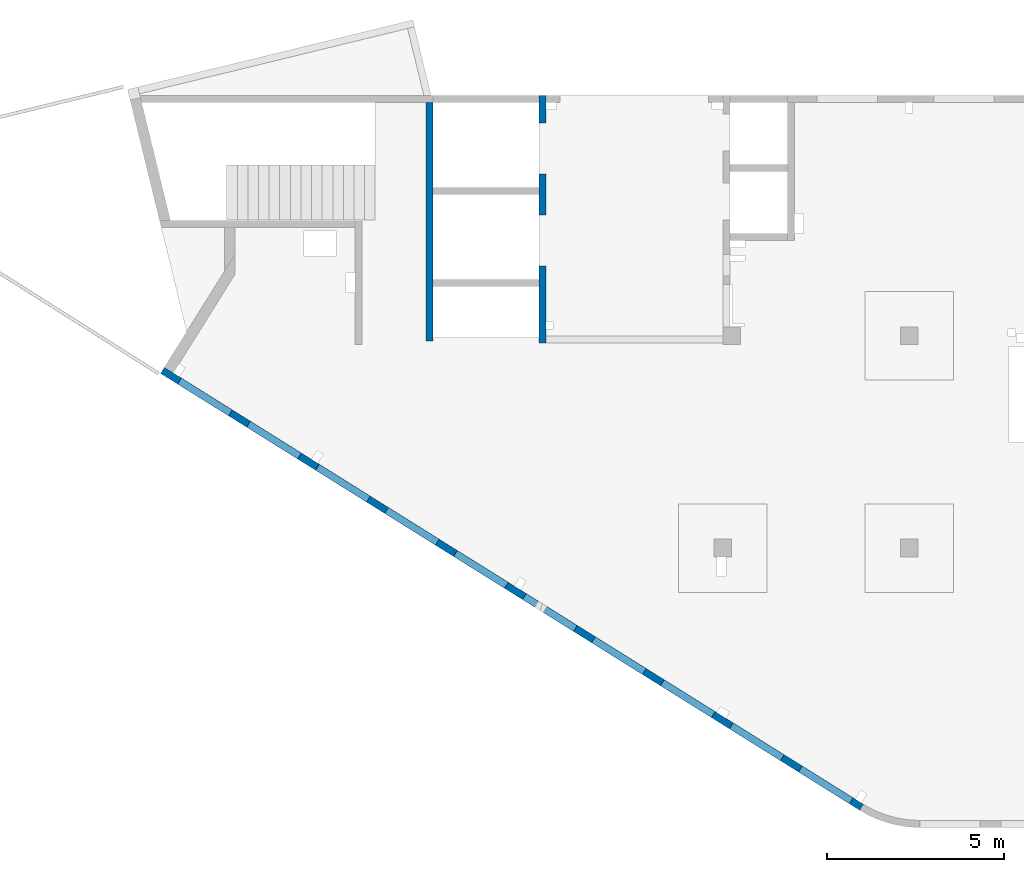
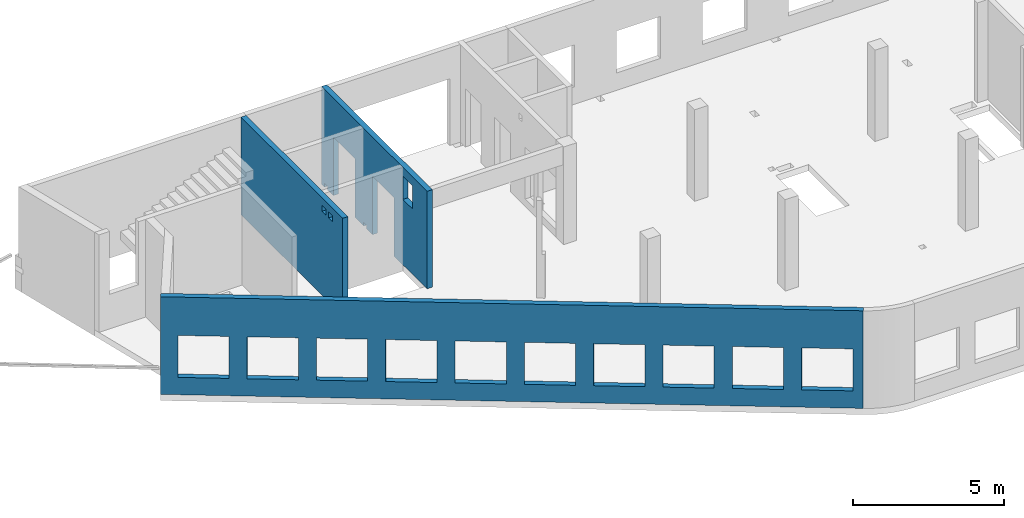
# One storey, part 5 of 8: 3 walls, 17 openings.
"""IFC4 building model written with IfcOpenShell, lengths in millimetres."""

import ifcopenshell
import ifcopenshell.guid

model = None  # the IFC model being written
_history = None  # IfcOwnerHistory: only IFC2X3 demands one
_inside = {}  # id of a spatial element -> (the spatial element, [elements in it])
_under = {}  # id of a project, library or spatial element -> (it, [spatial elements below it])
_declared = {}  # id of a project -> (the project, [libraries it declares])
_typed = {}  # id of a type object -> (the type object, [elements of that type])
_made_of = {}  # id of a material, layer set ... -> (it, [elements and type objects made of it])


def new_model(schema):
    """Start an empty IFC model of exactly this schema.

    Asked for "IFC4X3", IfcOpenShell would pick the latest addendum, in which some entities
    have other attributes; the version numbers below select the first issue.
    IFC2X3 requires an IfcOwnerHistory on every rooted entity: one is made here for all.
    """
    global model, _history
    if schema == "IFC4X3":
        model = ifcopenshell.file(schema_version=(4, 3, 0, 0))
    else:
        model = ifcopenshell.file(schema=schema)
    _inside.clear()
    _under.clear()
    _declared.clear()
    _typed.clear()
    _made_of.clear()
    _history = None
    if model.schema == "IFC2X3":
        org = make("IfcOrganization", Name="unknown")
        user = make(
            "IfcPersonAndOrganization",
            ThePerson=make("IfcPerson", FamilyName="unknown"),
            TheOrganization=org,
        )
        app = make(
            "IfcApplication",
            ApplicationDeveloper=org,
            Version="unknown",
            ApplicationFullName="unknown",
            ApplicationIdentifier="unknown",
        )
        _history = make(
            "IfcOwnerHistory",
            OwningUser=user,
            OwningApplication=app,
            ChangeAction="ADDED",
            CreationDate=0,
        )
    return model


def make(cls, **values):
    """One entity of the class cls with the attributes given. An attribute that is None is left unset."""
    return model.create_entity(
        cls, **{name: value for name, value in values.items() if value is not None}
    )


def entity(cls, *values):
    """Any entity or typed value of the class cls, its attributes in the order of the schema. None: left unset."""
    e = model.create_entity(cls)
    for i, value in enumerate(values):
        if value is not None:
            e[i] = value
    return e


def rooted(cls, **values):
    """An entity with a GlobalId (a new one), such as an element, a storey or a relation."""
    return make(cls, GlobalId=ifcopenshell.guid.new(), OwnerHistory=_history, **values)


def si_unit(unit_type, name, prefix=None):
    """IfcSIUnit, for example si_unit("LENGTHUNIT", "METRE", prefix="MILLI")."""
    return make("IfcSIUnit", UnitType=unit_type, Prefix=prefix, Name=name)


def converted_unit(unit_type, name, factor, base, dimensions=None, offset=None):
    """IfcConversionBasedUnit, such as the inch: factor (a typed value) times the base unit."""
    return make(
        "IfcConversionBasedUnit"
        if offset is None
        else "IfcConversionBasedUnitWithOffset",
        ConversionOffset=offset,
        Dimensions=None
        if dimensions is None
        else entity("IfcDimensionalExponents", *dimensions),
        UnitType=unit_type,
        Name=name,
        ConversionFactor=make(
            "IfcMeasureWithUnit", ValueComponent=factor, UnitComponent=base
        ),
    )


def derived_unit(unit_type, elements):
    """IfcDerivedUnit: a product of units, each with its exponent."""
    return make(
        "IfcDerivedUnit",
        Elements=[
            make("IfcDerivedUnitElement", Unit=unit, Exponent=power)
            for unit, power in elements
        ],
        UnitType=unit_type,
    )


def assignment(units):
    """IfcUnitAssignment: the units of a project."""
    return None if units is None else make("IfcUnitAssignment", Units=units)


def point(xyz):
    """IfcCartesianPoint."""
    return None if xyz is None else make("IfcCartesianPoint", Coordinates=xyz)


def direction(xyz):
    """IfcDirection."""
    return None if xyz is None else make("IfcDirection", DirectionRatios=xyz)


def frame(location, z_axis=None, x_axis=None):
    """IfcAxis2Placement3D, a coordinate frame: its origin and axes. An axis left out is left unset."""
    return make(
        "IfcAxis2Placement3D",
        Location=point(location),
        Axis=direction(z_axis),
        RefDirection=direction(x_axis),
    )


def origin():
    """The frame at (0, 0, 0) with its axes left unset."""
    return frame((0.0, 0.0, 0.0))


def place(relative_to, where):
    """IfcLocalPlacement: puts the frame where relative to a parent placement (None: the world)."""
    return make(
        "IfcLocalPlacement", PlacementRelTo=relative_to, RelativePlacement=where
    )


def context(
    kind, dimensions, precision=None, world=None, true_north=None, identifier=None
):
    """IfcGeometricRepresentationContext, for example the 3D "Model" context."""
    return make(
        "IfcGeometricRepresentationContext",
        ContextIdentifier=identifier,
        ContextType=kind,
        CoordinateSpaceDimension=dimensions,
        Precision=precision,
        WorldCoordinateSystem=world,
        TrueNorth=true_north,
    )


def subcontext(parent, identifier, kind, view, scale=None):
    """IfcGeometricRepresentationSubContext, for example "Body" below "Model"."""
    return make(
        "IfcGeometricRepresentationSubContext",
        ContextIdentifier=identifier,
        ContextType=kind,
        ParentContext=parent,
        TargetScale=scale,
        TargetView=view,
    )


def project(units=None, contexts=None):
    """IfcProject with its units and contexts."""
    return rooted(
        "IfcProject",
        Name="project",
        RepresentationContexts=contexts,
        UnitsInContext=assignment(units),
    )


def spatial(cls, under=None, at=None, **own):
    """A site, building, storey or space (cls), placed at a placement, below another one or the project."""
    s = rooted(cls, ObjectPlacement=at, **own)
    if under is not None:
        _under.setdefault(under.id(), (under, []))[1].append(s)
    return s


def point_list(points):
    """IfcCartesianPointList2D or 3D."""
    cls = (
        "IfcCartesianPointList2D" if len(points[0]) == 2 else "IfcCartesianPointList3D"
    )
    return make(cls, CoordList=points)


def indexed_curve(points, segments=None, self_intersect=None):
    """IfcIndexedPolyCurve: lines and arcs through numbered points (the first is 1)."""
    return make(
        "IfcIndexedPolyCurve",
        Points=point_list(points),
        Segments=segments,
        SelfIntersect=self_intersect,
    )


def outline(outer, holes=None, kind="AREA"):
    """IfcArbitraryClosedProfileDef: a profile drawn as a closed curve; with holes, ...WithVoids."""
    if holes is None:
        return make("IfcArbitraryClosedProfileDef", ProfileType=kind, OuterCurve=outer)
    return make(
        "IfcArbitraryProfileDefWithVoids",
        ProfileType=kind,
        OuterCurve=outer,
        InnerCurves=holes,
    )


def extrude(swept, where, along, depth):
    """IfcExtrudedAreaSolid: the profile swept, set in the frame where, extruded along a direction by depth."""
    return make(
        "IfcExtrudedAreaSolid",
        SweptArea=swept,
        Position=where,
        ExtrudedDirection=direction(along),
        Depth=depth,
    )


def polygons(points, faces, closed=None, point_numbers=None):
    """IfcPolygonalFaceSet: a face is its outer loop, then its inner loops; points numbered from 1."""
    made = []
    for loops in faces:
        if len(loops) == 1:
            made.append(make("IfcIndexedPolygonalFace", CoordIndex=loops[0]))
        else:
            made.append(
                make(
                    "IfcIndexedPolygonalFaceWithVoids",
                    CoordIndex=loops[0],
                    InnerCoordIndices=loops[1:],
                )
            )
    return make(
        "IfcPolygonalFaceSet",
        Coordinates=point_list(points),
        Closed=closed,
        Faces=made,
        PnIndex=point_numbers,
    )


def shape(context_of_items, identifier, shape_type, items):
    """IfcShapeRepresentation: the items that make up one representation, for example the "Body"."""
    return make(
        "IfcShapeRepresentation",
        ContextOfItems=context_of_items,
        RepresentationIdentifier=identifier,
        RepresentationType=shape_type,
        Items=items,
    )


def material(Name=None, Category=None):
    """IfcMaterial."""
    return make("IfcMaterial", Name=Name, Category=Category)


def made_of(thing, what):
    """Note that an element or type object is made of a material, layer set ...; save() writes the relation."""
    if what is not None:
        _made_of.setdefault(what.id(), (what, []))[1].append(thing)
    return thing


def type_object(cls, material=None, **own):
    """A type object (cls), such as IfcWallType, which elements share."""
    return made_of(rooted(cls, **own), material)


def element(
    cls,
    number,
    at=None,
    inside=None,
    cuts=None,
    type_object=None,
    material=None,
    context=None,
    identifier="Body",
    shape_type=None,
    held_by="IfcProductDefinitionShape",
    body=None,
    shapes=None,
    **own,
):
    """One element of the class cls, such as IfcWall. Its Tag is "e" and its number.

    at: its placement. inside: the storey or other place that contains it. cuts: it is an
    opening in that element (IfcRelVoidsElement). A single representation is given by context,
    identifier, shape_type and body (its items); several are given by shapes. held_by: the class
    of the entity that holds the representations. save() writes the other relations.
    """
    e = rooted(cls, Tag="e%d" % number, ObjectPlacement=at, **own)
    if body is not None:
        shapes = [shape(context, identifier, shape_type, body)]
    if shapes is not None:
        e.Representation = make(held_by, Representations=shapes)
    if inside is not None:
        _inside.setdefault(inside.id(), (inside, []))[1].append(e)
    if cuts is not None:
        rooted(
            "IfcRelVoidsElement", RelatingBuildingElement=cuts, RelatedOpeningElement=e
        )
    if type_object is not None:
        _typed.setdefault(type_object.id(), (type_object, []))[1].append(e)
    return made_of(e, material)


def aggregate(whole, parts):
    """IfcRelAggregates: a whole, such as a stair, and the parts it consists of."""
    return rooted("IfcRelAggregates", RelatingObject=whole, RelatedObjects=parts)


def save(model, path):
    """Write the relations noted so far, then the file.

    IfcRelAggregates (storeys below a building ...), IfcRelContainedInSpatialStructure (elements
    in a storey), IfcRelDefinesByType, IfcRelAssociatesMaterial and IfcRelDeclares: one each for
    every whole, place, type object, material and project.
    """
    for whole, parts in _under.values():
        aggregate(whole, parts)
    for where, things in _inside.values():
        rooted(
            "IfcRelContainedInSpatialStructure",
            RelatedElements=things,
            RelatingStructure=where,
        )
    for kind, things in _typed.values():
        rooted("IfcRelDefinesByType", RelatedObjects=things, RelatingType=kind)
    for what, things in _made_of.values():
        rooted("IfcRelAssociatesMaterial", RelatedObjects=things, RelatingMaterial=what)
    for by, libraries in _declared.values():
        rooted("IfcRelDeclares", RelatingContext=by, RelatedDefinitions=libraries)
    model.write(path)


model = new_model("IFC4")

# Units and contexts
model_context = context("Model", 3, precision=0.01, world=origin(), true_north=direction((6.12303176911189e-17, 1.0)))
plan_context = context("Plan", 3, precision=0.01, world=origin(), true_north=direction((6.12303176911189e-17, 1.0)))
body_context = subcontext(model_context, "Body", "Model", "MODEL_VIEW")
ifc_project = project(units=[si_unit("LENGTHUNIT", "METRE", prefix="MILLI"), si_unit("AREAUNIT", "SQUARE_METRE"), si_unit("VOLUMEUNIT", "CUBIC_METRE"), converted_unit("PLANEANGLEUNIT", "DEGREE", entity("IfcRatioMeasure", 0.0174532925199433), si_unit("PLANEANGLEUNIT", "RADIAN"), dimensions=[0, 0, 0, 0, 0, 0, 0]), si_unit("MASSUNIT", "GRAM", prefix="KILO"), derived_unit("MASSDENSITYUNIT", [(si_unit("MASSUNIT", "GRAM", prefix="KILO"), 1), (si_unit("LENGTHUNIT", "METRE"), -3)]), derived_unit("MOMENTOFINERTIAUNIT", [(si_unit("LENGTHUNIT", "METRE"), 4)]), si_unit("TIMEUNIT", "SECOND"), si_unit("FREQUENCYUNIT", "HERTZ"), si_unit("THERMODYNAMICTEMPERATUREUNIT", "DEGREE_CELSIUS"), derived_unit("THERMALTRANSMITTANCEUNIT", [(si_unit("MASSUNIT", "GRAM", prefix="KILO"), 1), (si_unit("THERMODYNAMICTEMPERATUREUNIT", "KELVIN"), -1), (si_unit("TIMEUNIT", "SECOND"), -3)]), derived_unit("VOLUMETRICFLOWRATEUNIT", [(si_unit("LENGTHUNIT", "METRE"), 3), (si_unit("TIMEUNIT", "SECOND"), -1)]), derived_unit("MASSFLOWRATEUNIT", [(si_unit("MASSUNIT", "GRAM", prefix="KILO"), 1), (si_unit("TIMEUNIT", "SECOND"), -1)]), derived_unit("ROTATIONALFREQUENCYUNIT", [(si_unit("TIMEUNIT", "SECOND"), -1)]), si_unit("ELECTRICCURRENTUNIT", "AMPERE"), si_unit("ELECTRICVOLTAGEUNIT", "VOLT"), si_unit("POWERUNIT", "WATT"), si_unit("FORCEUNIT", "NEWTON", prefix="KILO"), si_unit("ILLUMINANCEUNIT", "LUX"), si_unit("LUMINOUSFLUXUNIT", "LUMEN"), si_unit("LUMINOUSINTENSITYUNIT", "CANDELA"), derived_unit("USERDEFINED", [(si_unit("MASSUNIT", "GRAM", prefix="KILO"), -1), (si_unit("LENGTHUNIT", "METRE"), -2), (si_unit("TIMEUNIT", "SECOND"), 3), (si_unit("LUMINOUSFLUXUNIT", "LUMEN"), 1)]), derived_unit("LINEARVELOCITYUNIT", [(si_unit("LENGTHUNIT", "METRE"), 1), (si_unit("TIMEUNIT", "SECOND"), -1)]), si_unit("PRESSUREUNIT", "PASCAL"), derived_unit("USERDEFINED", [(si_unit("LENGTHUNIT", "METRE"), -2), (si_unit("MASSUNIT", "GRAM", prefix="KILO"), 1), (si_unit("TIMEUNIT", "SECOND"), -2)]), derived_unit("LINEARFORCEUNIT", [(si_unit("MASSUNIT", "GRAM", prefix="KILO"), 1), (si_unit("LENGTHUNIT", "METRE"), 1), (si_unit("TIMEUNIT", "SECOND"), -2), (si_unit("LENGTHUNIT", "METRE"), -1)]), derived_unit("PLANARFORCEUNIT", [(si_unit("MASSUNIT", "GRAM", prefix="KILO"), 1), (si_unit("LENGTHUNIT", "METRE"), 1), (si_unit("TIMEUNIT", "SECOND"), -2), (si_unit("LENGTHUNIT", "METRE"), -2)])], contexts=[model_context, plan_context])

# Site, building, storey
site_placement = place(None, origin())
site = spatial("IfcSite", under=ifc_project, at=site_placement, CompositionType="ELEMENT")
building_placement = place(site_placement, origin())
building = spatial("IfcBuilding", under=site, at=building_placement, CompositionType="ELEMENT")
storey_placement = place(building_placement, frame((0.0, 0.0, 24000.0)))
storey = spatial("IfcBuildingStorey", under=building, at=storey_placement, CompositionType="ELEMENT", Elevation=24000.0)

# Wall, openings
ifc_material = material()
wall_type = type_object("IfcWallType", PredefinedType="STANDARD")
wall_1_placement = place(storey_placement, frame((19823.5077523203, 370.436535143524, -150.0), z_axis=(0.0, 0.0, 1.0), x_axis=(-0.848052743777574, 0.529911826412025, 0.0)))
wall_1 = element("IfcWall", 1, at=wall_1_placement, inside=storey, type_object=wall_type, material=ifc_material, PredefinedType="NOTDEFINED", context=body_context, shape_type="Tessellation", body=[
    polygons([(-1.45510270499472e-12, -99.9999999999999, 0.0), (23013.0035862376, -99.9999999999989, 0.0), (23313.0035862376, -99.9999999999989, 0.0), (23313.0035862376, -99.9999999999989, 3950.0), (23013.0035862376, -99.9999999999989, 3950.0), (18403.0035862376, -99.9999999999989, 3950.0), (18103.0035862376, -100.0, 3950.0), (-1.45510270499472e-12, -99.9999999999999, 3950.0), (343.003167803934, -99.9999999999988, 2400.0), (2043.00316780393, -99.9999999999981, 2400.0), (2043.00316780393, -99.9999999999981, 700.00000000001), (343.003167803934, -99.9999999999988, 700.00000000001), (2643.00316780394, -99.9999999999995, 2400.0), (4343.00316780394, -99.9999999999992, 2400.0), (4343.00316780394, -99.9999999999992, 700.00000000001), (2643.00316780394, -99.9999999999995, 700.00000000001), (4943.00316780394, -100.0, 2400.0), (6643.00316780394, -99.9999999999984, 2400.0), (6643.00316780394, -99.9999999999984, 700.00000000001), (4943.00316780394, -100.0, 700.00000000001), (7243.00316780395, -99.9999999999984, 2400.0), (8943.00316780395, -100.0, 2400.0), (8943.00316780395, -100.0, 700.00000000001), (7243.00316780395, -99.9999999999984, 700.00000000001), (9543.00316780396, -100.0, 2400.0), (11243.003167804, -99.9999999999989, 2400.0), (11243.003167804, -99.9999999999989, 700.00000000001), (9543.00316780396, -100.0, 700.00000000001), (11843.003167804, -100.0, 2400.0), (13543.003167804, -100.0, 2400.0), (13543.003167804, -100.0, 700.00000000001), (11843.003167804, -100.0, 700.00000000001), (14143.003167804, -100.0, 2400.0), (15843.003167804, -100.0, 2400.0), (15843.003167804, -100.0, 700.00000000001), (14143.003167804, -100.0, 700.00000000001), (16443.003167804, -99.9999999999989, 2400.0), (18143.003167804, -99.9999999999989, 2400.0), (18143.003167804, -99.9999999999989, 700.00000000001), (16443.003167804, -99.9999999999989, 700.00000000001), (18743.003167804, -100.0, 2400.0), (20443.003167804, -99.9999999999989, 2400.0), (20443.003167804, -99.9999999999989, 700.00000000001), (18743.003167804, -100.0, 700.00000000001), (21043.003167804, -99.9999999999989, 2400.0), (22743.003167804, -100.000000000001, 2400.0), (22743.003167804, -100.000000000001, 700.00000000001), (21043.003167804, -99.9999999999989, 700.00000000001), (-2.21649365528265e-12, 100.000000000001, 0.0), (-2.18265405749207e-12, 100.000000000001, 3950.0), (1.38633244452641, 99.9999999999989, 3950.0), (23313.0035862376, 99.9999999999989, 3950.0), (23313.0035862376, 99.9999999999989, 0.0), (2043.00316780394, 100.000000000323, 2400.0), (343.003167803935, 100.000000000321, 2400.0), (343.003167803935, 100.000000000321, 700.00000000001), (2043.00316780394, 100.000000000323, 700.00000000001), (4343.00316780394, 100.000000000322, 2400.0), (2643.00316780394, 100.00000000032, 2400.0), (2643.00316780394, 100.00000000032, 700.00000000001), (4343.00316780394, 100.000000000322, 700.00000000001), (6643.00316780395, 100.000000000322, 2400.0), (4943.00316780394, 100.000000000321, 2400.0), (4943.00316780394, 100.000000000321, 700.00000000001), (6643.00316780395, 100.000000000322, 700.00000000001), (8943.00316780395, 100.000000000321, 2400.0), (7243.00316780395, 100.000000000322, 2400.0), (7243.00316780395, 100.000000000322, 700.00000000001), (8943.00316780395, 100.000000000321, 700.00000000001), (11243.003167804, 100.000000000323, 2400.0), (9543.00316780396, 100.000000000321, 2400.0), (9543.00316780396, 100.000000000321, 700.00000000001), (11243.003167804, 100.000000000323, 700.00000000001), (13543.003167804, 100.000000000319, 2400.0), (11843.003167804, 100.000000000323, 2400.0), (11843.003167804, 100.000000000323, 700.00000000001), (13543.003167804, 100.000000000319, 700.00000000001), (15843.003167804, 100.000000000322, 2400.0), (14143.003167804, 100.000000000322, 2400.0), (14143.003167804, 100.000000000322, 700.00000000001), (15843.003167804, 100.000000000322, 700.00000000001), (18143.003167804, 100.000000000322, 2400.0), (16443.003167804, 100.000000000322, 2400.0), (16443.003167804, 100.000000000322, 700.00000000001), (18143.003167804, 100.000000000322, 700.00000000001), (20443.003167804, 100.000000000322, 2400.0), (18743.003167804, 100.000000000319, 2400.0), (18743.003167804, 100.000000000319, 700.00000000001), (20443.003167804, 100.000000000322, 700.00000000001), (22743.003167804, 100.000000000319, 2400.0), (21043.003167804, 100.000000000321, 2400.0), (21043.003167804, 100.000000000323, 700.00000000001), (22743.003167804, 100.000000000319, 700.00000000001)], [[[1, 2, 3, 4, 5, 6, 7, 8], [9, 10, 11, 12], [13, 14, 15, 16], [17, 18, 19, 20], [21, 22, 23, 24], [25, 26, 27, 28], [29, 30, 31, 32], [33, 34, 35, 36], [37, 38, 39, 40], [41, 42, 43, 44], [45, 46, 47, 48]], [[49, 50, 51, 52, 53], [54, 55, 56, 57], [58, 59, 60, 61], [62, 63, 64, 65], [66, 67, 68, 69], [70, 71, 72, 73], [74, 75, 76, 77], [78, 79, 80, 81], [82, 83, 84, 85], [86, 87, 88, 89], [90, 91, 92, 93]], [[3, 2, 1, 49, 53]], [[8, 7, 6, 5, 4, 52, 51, 50]], [[1, 8, 50, 49]], [[4, 3, 53, 52]], [[55, 54, 10, 9]], [[55, 9, 12, 56]], [[56, 12, 11, 57]], [[10, 54, 57, 11]], [[59, 58, 14, 13]], [[59, 13, 16, 60]], [[60, 16, 15, 61]], [[14, 58, 61, 15]], [[63, 62, 18, 17]], [[63, 17, 20, 64]], [[64, 20, 19, 65]], [[18, 62, 65, 19]], [[67, 66, 22, 21]], [[67, 21, 24, 68]], [[68, 24, 23, 69]], [[22, 66, 69, 23]], [[71, 70, 26, 25]], [[71, 25, 28, 72]], [[72, 28, 27, 73]], [[26, 70, 73, 27]], [[75, 74, 30, 29]], [[75, 29, 32, 76]], [[76, 32, 31, 77]], [[30, 74, 77, 31]], [[79, 78, 34, 33]], [[79, 33, 36, 80]], [[80, 36, 35, 81]], [[34, 78, 81, 35]], [[83, 82, 38, 37]], [[83, 37, 40, 84]], [[84, 40, 39, 85]], [[38, 82, 85, 39]], [[87, 86, 42, 41]], [[87, 41, 44, 88]], [[88, 44, 43, 89]], [[42, 86, 89, 43]], [[91, 90, 46, 45]], [[91, 45, 48, 92]], [[92, 48, 47, 93]], [[46, 90, 93, 47]]], closed=True),
])
opening_1_placement = place(wall_1_placement, frame((16615.0814397436, 10818.8609189489, 150.0), z_axis=(0.0, 0.0, 1.0), x_axis=(-0.848052743777574, -0.529911826412026, 0.0)))
element("IfcOpeningElement", 2, at=opening_1_placement, cuts=wall_1, PredefinedType="OPENING", context=body_context, shape_type="SweptSolid", body=[
    extrude(outline(indexed_curve([(-849.999999999993, -850.0), (849.999999999993, -850.0), (849.999999999993, 850.0), (-849.999999999993, 850.0), (-849.999999999993, -850.0)], self_intersect=False)), frame((1310.07752897417, 12056.6031038165, 1400.0), z_axis=(-0.529911826412026, -0.848052743777574, 0.0), x_axis=(0.0, 0.0, -1.0)), (0.0, 0.0, 1.0), 200.000000000964),
])
opening_2_placement = place(wall_1_placement, frame((16615.0814397436, 10818.8609189489, 150.0), z_axis=(0.0, 0.0, 1.0), x_axis=(-0.848052743777574, -0.529911826412026, 0.0)))
element("IfcOpeningElement", 3, at=opening_2_placement, cuts=wall_1, PredefinedType="OPENING", context=body_context, shape_type="SweptSolid", body=[
    extrude(outline(indexed_curve([(-849.999999999993, -850.0), (849.999999999993, -850.0), (849.999999999993, 850.0), (-849.999999999993, 850.0), (-849.999999999993, -850.0)], self_intersect=False)), frame((3260.5988396626, 10837.8059030689, 1400.0), z_axis=(-0.529911826412026, -0.848052743777574, 0.0), x_axis=(0.0, 0.0, -1.0)), (0.0, 0.0, 1.0), 200.000000000964),
])
opening_3_placement = place(wall_1_placement, frame((16615.0814397436, 10818.8609189489, 150.0), z_axis=(0.0, 0.0, 1.0), x_axis=(-0.848052743777574, -0.529911826412026, 0.0)))
element("IfcOpeningElement", 4, at=opening_3_placement, cuts=wall_1, PredefinedType="OPENING", context=body_context, shape_type="SweptSolid", body=[
    extrude(outline(indexed_curve([(-849.999999999993, -850.0), (849.999999999993, -850.0), (849.999999999993, 850.0), (-849.999999999993, 850.0), (-849.999999999993, -850.0)], self_intersect=False)), frame((5211.12015035101, 9619.00870232123, 1400.0), z_axis=(-0.529911826412025, -0.848052743777574, 0.0), x_axis=(0.0, 0.0, -1.0)), (0.0, 0.0, 1.0), 200.000000000962),
])
opening_4_placement = place(wall_1_placement, frame((16615.0814397436, 10818.8609189489, 150.0), z_axis=(0.0, 0.0, 1.0), x_axis=(-0.848052743777574, -0.529911826412026, 0.0)))
element("IfcOpeningElement", 5, at=opening_4_placement, cuts=wall_1, PredefinedType="OPENING", context=body_context, shape_type="SweptSolid", body=[
    extrude(outline(indexed_curve([(-849.999999999993, -849.999999999999), (849.999999999993, -849.999999999999), (849.999999999993, 850.0), (-849.999999999993, 850.0), (-849.999999999993, -849.999999999999)], self_intersect=False)), frame((7161.64146103944, 8400.21150157357, 1400.0), z_axis=(-0.529911826412026, -0.848052743777574, 0.0), x_axis=(0.0, 0.0, -1.0)), (0.0, 0.0, 1.0), 200.000000000962),
])
opening_5_placement = place(wall_1_placement, frame((16615.0814397436, 10818.8609189489, 150.0), z_axis=(0.0, 0.0, 1.0), x_axis=(-0.848052743777574, -0.529911826412026, 0.0)))
element("IfcOpeningElement", 6, at=opening_5_placement, cuts=wall_1, PredefinedType="OPENING", context=body_context, shape_type="SweptSolid", body=[
    extrude(outline(indexed_curve([(-849.999999999993, -849.999999999999), (849.999999999993, -849.999999999999), (849.999999999993, 850.0), (-849.999999999993, 850.0), (-849.999999999993, -849.999999999999)], self_intersect=False)), frame((9112.16277172786, 7181.41430082591, 1400.0), z_axis=(-0.529911826412026, -0.848052743777574, 0.0), x_axis=(0.0, 0.0, -1.0)), (0.0, 0.0, 1.0), 200.000000000962),
])
opening_6_placement = place(wall_1_placement, frame((16615.0814397436, 10818.8609189489, 150.0), z_axis=(0.0, 0.0, 1.0), x_axis=(-0.848052743777574, -0.529911826412026, 0.0)))
element("IfcOpeningElement", 7, at=opening_6_placement, cuts=wall_1, PredefinedType="OPENING", context=body_context, shape_type="SweptSolid", body=[
    extrude(outline(indexed_curve([(-849.999999999993, -850.0), (849.999999999993, -850.0), (849.999999999993, 850.0), (-849.999999999993, 850.0), (-849.999999999993, -850.0)], self_intersect=False)), frame((11062.6840824163, 5962.61710007824, 1400.0), z_axis=(-0.529911826412025, -0.848052743777574, 0.0), x_axis=(0.0, 0.0, -1.0)), (0.0, 0.0, 1.0), 200.000000000964),
])
opening_7_placement = place(wall_1_placement, frame((16615.0814397436, 10818.8609189489, 150.0), z_axis=(0.0, 0.0, 1.0), x_axis=(-0.848052743777574, -0.529911826412026, 0.0)))
element("IfcOpeningElement", 8, at=opening_7_placement, cuts=wall_1, PredefinedType="OPENING", context=body_context, shape_type="SweptSolid", body=[
    extrude(outline(indexed_curve([(-849.999999999993, -850.0), (849.999999999993, -850.0), (849.999999999993, 850.0), (-849.999999999993, 850.0), (-849.999999999993, -850.0)], self_intersect=False)), frame((13013.2053931047, 4743.81989933058, 1400.0), z_axis=(-0.529911826412025, -0.848052743777574, 0.0), x_axis=(0.0, 0.0, -1.0)), (0.0, 0.0, 1.0), 200.000000000959),
])
opening_8_placement = place(wall_1_placement, frame((16615.0814397436, 10818.8609189489, 150.0), z_axis=(0.0, 0.0, 1.0), x_axis=(-0.848052743777574, -0.529911826412026, 0.0)))
element("IfcOpeningElement", 9, at=opening_8_placement, cuts=wall_1, PredefinedType="OPENING", context=body_context, shape_type="SweptSolid", body=[
    extrude(outline(indexed_curve([(-849.999999999993, -850.000000000002), (849.999999999993, -850.000000000002), (849.999999999993, 849.999999999998), (-849.999999999993, 849.999999999998), (-849.999999999993, -850.000000000002)], self_intersect=False)), frame((14963.7267037931, 3525.02269858292, 1400.0), z_axis=(-0.529911826412025, -0.848052743777574, 0.0), x_axis=(0.0, 0.0, -1.0)), (0.0, 0.0, 1.0), 200.000000000962),
])
opening_9_placement = place(wall_1_placement, frame((16615.0814397436, 10818.8609189489, 150.0), z_axis=(0.0, 0.0, 1.0), x_axis=(-0.848052743777574, -0.529911826412026, 0.0)))
element("IfcOpeningElement", 10, at=opening_9_placement, cuts=wall_1, PredefinedType="OPENING", context=body_context, shape_type="SweptSolid", body=[
    extrude(outline(indexed_curve([(-849.999999999993, -850.0), (849.999999999993, -850.0), (849.999999999993, 850.0), (-849.999999999993, 850.0), (-849.999999999993, -850.0)], self_intersect=False)), frame((16914.2480144816, 2306.22549783526, 1400.0), z_axis=(-0.529911826412025, -0.848052743777574, 0.0), x_axis=(0.0, 0.0, -1.0)), (0.0, 0.0, 1.0), 200.000000000962),
])
opening_10_placement = place(wall_1_placement, frame((16615.0814397436, 10818.8609189489, 150.0), z_axis=(0.0, 0.0, 1.0), x_axis=(-0.848052743777574, -0.529911826412026, 0.0)))
element("IfcOpeningElement", 11, at=opening_10_placement, cuts=wall_1, PredefinedType="OPENING", context=body_context, shape_type="SweptSolid", body=[
    extrude(outline(indexed_curve([(-849.999999999993, -850.0), (849.999999999993, -850.0), (849.999999999993, 850.0), (-849.999999999993, 850.0), (-849.999999999993, -850.0)], self_intersect=False)), frame((18864.76932517, 1087.4282970876, 1400.0), z_axis=(-0.529911826412025, -0.848052743777574, 0.0), x_axis=(0.0, 0.0, -1.0)), (0.0, 0.0, 1.0), 200.000000000966),
])

wall_2_placement = place(storey_placement, frame((7600.0002685547, 20299.9998657227, -150.0), z_axis=(0.0, 0.0, 1.0), x_axis=(0.0, -1.0, 0.0)))
wall_2 = element("IfcWall", 12, at=wall_2_placement, inside=storey, type_object=wall_type, material=ifc_material, PredefinedType="NOTDEFINED", context=body_context, shape_type="Tessellation", body=[
    polygons([(0.0, -100.000000000001, 0.0), (6750.0006393668, -99.9999999999998, 0.0), (6750.0006393668, -99.9999999999998, 3950.0), (0.0, -100.000000000001, 3950.0), (5815.0, -100.0, 3400.00000000001), (5815.0, -100.0, 3650.0), (6065.0, -99.9999999999998, 3650.0), (6065.0, -99.9999999999998, 3400.00000000001), (5375.0, -100.000000000001, 3650.0), (5625.0, -100.0, 3650.0), (5625.0, -100.0, 3400.00000000001), (5375.0, -100.000000000001, 3400.00000000001), (5815.0, 100.000000000321, 3650.0), (5815.0, 100.000000000321, 3400.00000000001), (6065.0, 100.000000000321, 3400.00000000001), (6065.0, 100.000000000321, 3650.0), (6750.0006393668, 99.9999999999992, 0.0), (6650.00063936679, 100.0, 0.0), (0.0, 100.0, 0.0), (0.0, 100.0, 499.999999999999), (0.0, 100.0, 700.000000000001), (0.0, 100.0, 3950.0), (2400.0, 99.9999999999999, 3950.0), (2600.0, 100.0, 3950.0), (5000.0, 100.000000000001, 3950.0), (5200.0, 100.0, 3950.0), (6600.0, 100.0, 3950.0), (6750.0006393668, 99.9999999999992, 3950.0), (5625.0, 100.000000000321, 3650.0), (5375.0, 100.000000000321, 3650.0), (5375.0, 100.000000000321, 3400.00000000001), (5625.0, 100.000000000321, 3400.00000000001)], [[[1, 2, 3, 4], [5, 6, 7, 8], [9, 10, 11, 12]], [[17, 18, 19, 20, 21, 22, 23, 24, 25, 26, 27, 28], [13, 14, 15, 16], [29, 30, 31, 32]], [[2, 1, 19, 18, 17]], [[3, 2, 17, 28]], [[4, 3, 28, 27, 26, 25, 24, 23, 22]], [[6, 13, 16, 7]], [[13, 6, 5, 14]], [[14, 5, 8, 15]], [[7, 16, 15, 8]], [[9, 30, 29, 10]], [[30, 9, 12, 31]], [[31, 12, 11, 32]], [[10, 29, 32, 11]], [[4, 22, 21, 20, 19, 1]]], closed=True),
])
opening_11_placement = place(wall_2_placement, frame((20299.9998657227, -7600.0002685547, 150.0), z_axis=(0.0, 0.0, 1.0), x_axis=(0.0, 1.0, 0.0)))
element("IfcOpeningElement", 13, at=opening_11_placement, cuts=wall_2, PredefinedType="OPENING", context=body_context, shape_type="SweptSolid", body=[
    extrude(outline(indexed_curve([(-124.999999999993, -125.0), (124.999999999993, -125.0), (124.999999999993, 125.0), (-124.999999999993, 125.0), (-124.999999999993, -125.0)], self_intersect=False)), frame((7500.00026855469, 14799.9998657227, 3375.0), z_axis=(1.0, 0.0, 0.0), x_axis=(0.0, 0.0, -1.0)), (0.0, 0.0, 1.0), 200.000000000962),
])
opening_12_placement = place(wall_2_placement, frame((20299.9998657227, -7600.0002685547, 150.0), z_axis=(0.0, 0.0, 1.0), x_axis=(0.0, 1.0, 0.0)))
element("IfcOpeningElement", 14, at=opening_12_placement, cuts=wall_2, PredefinedType="OPENING", context=body_context, shape_type="SweptSolid", body=[
    extrude(outline(indexed_curve([(-124.999999999993, -125.0), (124.999999999993, -125.0), (124.999999999993, 125.0), (-124.999999999993, 125.0), (-124.999999999993, -125.0)], self_intersect=False)), frame((7500.00026855469, 14359.9998657227, 3375.0), z_axis=(1.0, 0.0, 0.0), x_axis=(0.0, 0.0, -1.0)), (0.0, 0.0, 1.0), 200.000000000962),
])

wall_3_placement = place(storey_placement, frame((10800.0002685547, 20499.9998657227, -150.0), z_axis=(0.0, 0.0, 1.0), x_axis=(0.0, -1.0, 0.0)))
wall_3 = element("IfcWall", 15, at=wall_3_placement, inside=storey, type_object=wall_type, material=ifc_material, PredefinedType="NOTDEFINED", context=body_context, shape_type="Tessellation", body=[
    polygons([(5400.00000000002, -99.999999999999, 3600.0), (6050.00000000002, -99.9999999999979, 3600.0), (6050.00000000002, -99.9999999999979, 2650.00000000002), (5400.00000000002, -99.999999999999, 2650.00000000002), (7000.0006393668, -99.9999999999986, 3950.0), (6800.00000000001, -99.9999999999989, 3950.0), (5400.00000000002, -99.999999999999, 3950.0), (5200.00000000002, -99.9999999999993, 3950.0), (2800.00000000002, -99.9999999999987, 3950.0), (2600.00000000002, -99.9999999999991, 3950.0), (200.000000000028, -99.9999999999985, 3950.0), (0.0, -99.9999999999988, 3950.0), (0.0, -99.9999999999988, 0.0), (200.000639366303, -99.9999999999985, 0.0), (200.000639366303, -99.9999999999985, 149.999999999975), (400.000639366301, -99.9999999999982, 149.999999999975), (400.000639366301, -99.9999999999982, 0.0), (780.000000000018, -99.9999999999976, 0.0), (780.000000000018, -99.9999999999976, 2369.99999999805), (2220.00000000001, -99.9999999999975, 2369.99999999804), (2220.00000000001, -99.9999999999997, 0.0), (2800.00000000003, -99.9999999999987, 0.0), (2800.00000000003, -99.9999999999987, 149.999999999983), (3000.00000000003, -99.9999999999984, 149.999999999983), (3000.00000000003, -99.9999999999984, 0.0), (3380.00000000002, -99.9999999999978, 0.0), (3380.00000000002, -99.9999999999978, 2369.99999999805), (4820.00000000001, -99.9999999999977, 2369.99999999804), (4820.00000000001, -99.9999999999977, 0.0), (6850.00063936681, -99.9999999999988, 0.0), (7000.0006393668, -99.9999999999986, 0.0), (0.0, 100.000000000001, 3950.0), (200.000000000002, 100.000000000001, 3950.0), (6800.0006393668, 100.000000000001, 3950.0), (7000.0006393668, 100.000000000001, 3950.0), (7000.0006393668, 100.000000000001, 3200.0), (7000.0006393668, 100.000000000001, 0.0), (6600.0006393668, 100.000000000001, 0.0), (6400.0006393668, 100.0, 0.0), (4820.00000000001, 100.000000000002, 0.0), (4820.00000000002, 100.000000000002, 2369.99999999805), (3380.00000000002, 100.000000000002, 2369.99999999804), (3380.00000000002, 100.000000000002, 0.0), (3000.00000000003, 100.000000000002, 0.0), (3000.00000000003, 100.000000000322, 149.999999999983), (2800.00000000003, 100.000000000322, 149.999999999983), (2800.00000000003, 100.000000000001, 0.0), (2220.00000000001, 100.000000000003, 0.0), (2220.00000000001, 100.000000000003, 2369.99999999804), (780.000000000018, 100.000000000002, 2369.99999999805), (780.000000000018, 100.000000000002, 0.0), (400.000639366301, 100.000000000002, 0.0), (400.000639366301, 100.000000000322, 149.999999999975), (200.000639366303, 100.000000000322, 149.999999999975), (200.000639366303, 100.000000000001, 0.0), (0.0, 100.000000000001, 0.0), (6050.00000000002, 100.000000000323, 3600.0), (5400.00000000002, 100.000000000322, 3600.0), (5400.00000000002, 100.000000000322, 2650.00000000002), (6050.00000000002, 100.000000000323, 2650.00000000002)], [[[5, 6, 7, 8, 9, 10, 11, 12, 13, 14, 15, 16, 17, 18, 19, 20, 21, 22, 23, 24, 25, 26, 27, 28, 29, 30, 31], [1, 2, 3, 4]], [[32, 33, 34, 35, 36, 37, 38, 39, 40, 41, 42, 43, 44, 45, 46, 47, 48, 49, 50, 51, 52, 53, 54, 55, 56], [57, 58, 59, 60]], [[13, 56, 55, 14]], [[12, 11, 10, 9, 8, 7, 6, 5, 35, 34, 33, 32]], [[13, 12, 32, 56]], [[58, 57, 2, 1]], [[58, 1, 4, 59]], [[59, 4, 3, 60]], [[2, 57, 60, 3]], [[19, 50, 49, 20]], [[20, 49, 48, 21]], [[50, 19, 18, 51]], [[41, 28, 27, 42]], [[42, 27, 26, 43]], [[28, 41, 40, 29]], [[5, 31, 37, 36, 35]], [[15, 54, 53, 16]], [[54, 15, 14, 55]], [[16, 53, 52, 17]], [[23, 46, 45, 24]], [[46, 23, 22, 47]], [[24, 45, 44, 25]], [[21, 48, 47, 22]], [[31, 30, 29, 40, 39, 38, 37]], [[43, 26, 25, 44]], [[51, 18, 17, 52]]], closed=True),
])
opening_13_placement = place(wall_3_placement, frame((20499.9998657227, -10800.0002685547, 150.0), z_axis=(0.0, 0.0, 1.0), x_axis=(0.0, 1.0, 0.0)))
element("IfcOpeningElement", 16, at=opening_13_placement, cuts=wall_3, PredefinedType="OPENING", context=body_context, shape_type="SweptSolid", body=[
    extrude(outline(indexed_curve([(-719.999999999999, -1184.99999999902), (719.999999999999, -1184.99999999902), (719.999999999999, 1184.99999999902), (-719.999999999999, 1184.99999999902), (-719.999999999999, -1184.99999999902)], self_intersect=False)), frame((10600.0002685528, 18999.9998657227, 1035.0), z_axis=(1.0, 0.0, 0.0), x_axis=(0.0, -1.0, 0.0)), (0.0, 0.0, 1.0), 400.000000001943),
])
opening_14_placement = place(wall_3_placement, frame((20499.9998657227, -10800.0002685547, 150.0), z_axis=(0.0, 0.0, 1.0), x_axis=(0.0, 1.0, 0.0)))
element("IfcOpeningElement", 17, at=opening_14_placement, cuts=wall_3, PredefinedType="OPENING", context=body_context, shape_type="SweptSolid", body=[
    extrude(outline(indexed_curve([(-1184.99999999902, -719.999999999999), (1184.99999999902, -719.999999999999), (1184.99999999902, 720.000000000001), (-1184.99999999902, 720.000000000001), (-1184.99999999902, -719.999999999999)], self_intersect=False)), frame((10600.0002685547, 16399.9998657227, 1035.0), z_axis=(1.0, 0.0, 0.0), x_axis=(0.0, 0.0, -1.0)), (0.0, 0.0, 1.0), 400.000000001943),
])
opening_15_placement = place(wall_3_placement, frame((20499.9998657227, -10800.0002685547, 150.0), z_axis=(0.0, 0.0, 1.0), x_axis=(0.0, 1.0, 0.0)))
element("IfcOpeningElement", 18, at=opening_15_placement, cuts=wall_3, PredefinedType="OPENING", context=body_context, shape_type="SweptSolid", body=[
    extrude(outline(indexed_curve([(-74.9999999999916, -99.9999999999989), (74.9999999999916, -99.9999999999989), (74.9999999999916, 99.9999999999989), (-74.9999999999916, 99.9999999999989), (-74.9999999999916, -99.9999999999989)], self_intersect=False)), frame((10700.0002685547, 20199.9992263564, -75.0), z_axis=(1.0, 0.0, 0.0), x_axis=(0.0, 0.0, -1.0)), (0.0, 0.0, 1.0), 200.000000000962),
])
opening_16_placement = place(wall_3_placement, frame((20499.9998657227, -10800.0002685547, 150.0), z_axis=(0.0, 0.0, 1.0), x_axis=(0.0, 1.0, 0.0)))
element("IfcOpeningElement", 19, at=opening_16_placement, cuts=wall_3, PredefinedType="OPENING", context=body_context, shape_type="SweptSolid", body=[
    extrude(outline(indexed_curve([(-74.9999999999916, -100.000000000001), (74.9999999999916, -100.000000000001), (74.9999999999916, 99.9999999999989), (-74.9999999999916, 99.9999999999989), (-74.9999999999916, -100.000000000001)], self_intersect=False)), frame((10700.0002685547, 17599.9998657227, -75.0), z_axis=(1.0, 0.0, 0.0), x_axis=(0.0, 0.0, -1.0)), (0.0, 0.0, 1.0), 200.000000000962),
])
opening_17_placement = place(wall_3_placement, frame((20499.9998657227, -10800.0002685547, 150.0), z_axis=(0.0, 0.0, 1.0), x_axis=(0.0, 1.0, 0.0)))
element("IfcOpeningElement", 20, at=opening_17_placement, cuts=wall_3, PredefinedType="OPENING", context=body_context, shape_type="SweptSolid", body=[
    extrude(outline(indexed_curve([(-474.999999999996, -325.0), (474.999999999992, -325.0), (474.999999999992, 325.0), (-474.999999999996, 325.0), (-474.999999999996, -325.0)], self_intersect=False)), frame((10700.0002685547, 14774.9998657227, 2975.0), z_axis=(1.0, 0.0, 0.0), x_axis=(0.0, 0.0, -1.0)), (0.0, 0.0, 1.0), 200.000000000962),
])

save(model, "model.ifc")
